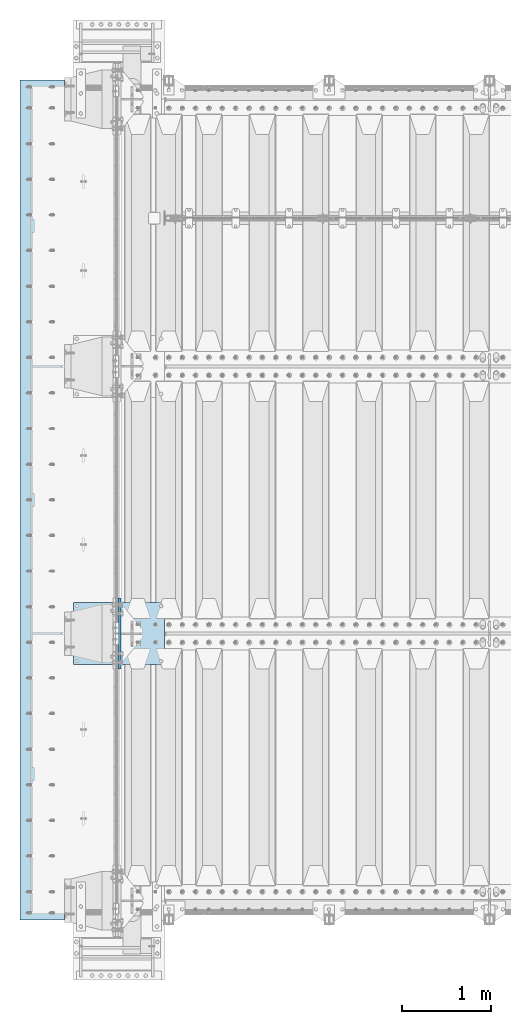
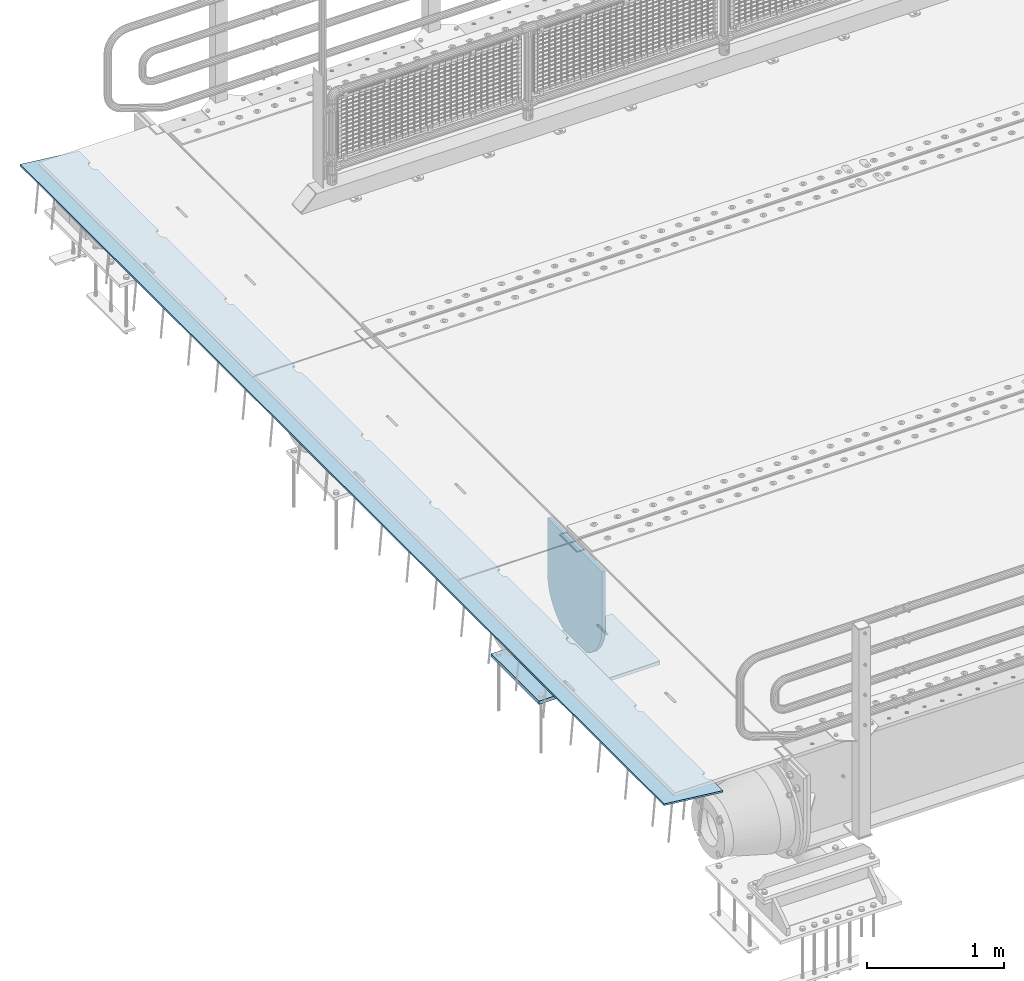
# One storey, part 169 of 219: 3 plates.
"""IFC2X3 building model written with IfcOpenShell, lengths in millimetres."""

from ifc_helpers import new_model, si_unit, frame, origin_with_axes, place, context, subcontext, project, spatial, faceted_brep, material, type_object, element, save


model = new_model("IFC2X3")

# Units and contexts
model_context = context("Model", 3, precision=1e-05, world=origin_with_axes())
body_context = subcontext(model_context, "Body", "Model", "MODEL_VIEW")
ifc_project = project(units=[si_unit("LENGTHUNIT", "METRE", prefix="MILLI"), si_unit("AREAUNIT", "SQUARE_METRE"), si_unit("VOLUMEUNIT", "CUBIC_METRE"), si_unit("MASSUNIT", "GRAM", prefix="KILO"), si_unit("TIMEUNIT", "SECOND"), si_unit("PLANEANGLEUNIT", "RADIAN"), si_unit("SOLIDANGLEUNIT", "STERADIAN"), si_unit("THERMODYNAMICTEMPERATUREUNIT", "DEGREE_CELSIUS"), si_unit("LUMINOUSINTENSITYUNIT", "LUMEN")], contexts=[model_context])

# Site, building, storey
site_placement = place(None, origin_with_axes())
site = spatial("IfcSite", under=ifc_project, at=site_placement, CompositionType="ELEMENT")
building_placement = place(site_placement, origin_with_axes())
building = spatial("IfcBuilding", under=site, at=building_placement, Name="Standard", CompositionType="ELEMENT")
storey_placement = place(building_placement, origin_with_axes())
storey = spatial("IfcBuildingStorey", under=building, at=storey_placement, Name="Undefined", CompositionType="ELEMENT", Elevation=0.0)

# Plates
ifc_material = material(Name="STEEL/S355N")
plate_type_1 = type_object("IfcPlateType", PredefinedType="NOTDEFINED")
plate_1_placement = place(storey_placement, frame((-624.181254970226, 23784.9999999981, -62.544823504668), z_axis=(-0.99402353270819, -1.00000033824219e-09, 0.109166003967953), x_axis=(0.0, 1.0, 0.0)))
element("IfcPlate", 1, at=plate_1_placement, inside=storey, type_object=plate_type_1, material=ifc_material, context=body_context, shape_type="Brep", body=[
    faceted_brep([(9165.000000001, -7.50000000000003, 7.55625608235277e-05), (9165.00000000271, 7.5, -1.22668097901624e-10), (9165.45576741756, 7.50000000000006, 5.20977563143788), (9165.45576741592, -7.50000000000003, 5.20977563143788), (9166.8092213894, 7.50000000000006, 10.260934599855), (9166.80922138775, -7.50000000000001, 10.260934599855), (9169.01923790418, 7.50000000000003, 15.000330297888), (9169.01923790254, -7.50000000000003, 15.000330297888), (9172.01866672843, 7.50000000000009, 19.283958585503), (9172.01866672678, -7.5, 19.2839585855029), (9175.71637173509, 7.50000000000003, 22.9816635848008), (9175.71637173346, -7.50000000000004, 22.9816635848008), (9180.00000002869, 7.50000000000003, 25.9810924005067), (9180.00000002705, -7.50000000000003, 25.9810924005067), (9184.73939573113, 7.50000000000009, 28.1911089058397), (9184.73939572949, -7.5, 28.1911089058397), (9189.79055470225, 7.50000000000006, 29.5445628676079), (9189.79055470061, -7.50000000000003, 29.5445628676079), (9195.00000003271, 7.50000000000003, 30.0003302720633), (9195.00000003107, -7.50000000000001, 30.0003302720631), (9235.00000003271, 7.50000000000003, 30.0003302323023), (9235.00000003107, -7.50000000000003, 30.0003302323022), (9240.20944536226, 7.50000000000006, 29.5445628174901), (9240.20944536063, -7.50000000000003, 29.5445628174901), (9245.26060433067, 7.50000000000003, 28.1911088456803), (9245.26060432904, -7.50000000000003, 28.1911088456803), (9250.00000002869, 7.50000000000006, 25.9810923309251), (9250.00000002705, -7.50000000000003, 25.981092330925), (9254.28362831629, 7.50000000000009, 22.9816635067032), (9254.28362831465, -7.50000000000003, 22.9816635067032), (9257.98133331556, 7.50000000000003, 19.2839585000545), (9257.98133331392, -7.50000000000004, 19.2839585000544), (9260.98076213124, 7.50000000000003, 15.000330206477), (9260.98076212961, -7.5, 15.0003302064769), (9263.19077863655, 7.50000000000006, 10.2609345040501), (9263.1907786349, -7.50000000000003, 10.2609345040501), (9264.54423259829, 7.50000000000003, 5.20977553294256), (9264.54423259664, -7.50000000000003, 5.20977553294244), (9265.00000000107, -7.50000000000001, 0.000330202481563902), (9265.00000000271, 7.5, -1.24146026792005e-10), (8265.00000000107, -7.50000000000001, 0.00033219055490008), (8264.54423259665, -7.50000000000001, 5.20977752101589), (8264.54423259829, 7.50000000000003, 5.20977752101589), (8265.00000000271, 7.50000000000003, -1.10617293103132e-10), (8263.19077863491, -7.5, 10.2609364921234), (8263.19077863655, 7.50000000000003, 10.2609364921234), (8260.98076212961, -7.50000000000001, 15.0003321945502), (8260.98076213124, 7.50000000000003, 15.0003321945502), (8257.98133331392, -7.5, 19.2839604881278), (8257.98133331557, 7.50000000000003, 19.2839604881278), (8254.28362831465, -7.50000000000003, 22.9816654947765), (8254.28362831629, 7.50000000000003, 22.9816654947766), (8250.00000002706, -7.50000000000001, 25.9810943189984), (8250.00000002869, 7.50000000000006, 25.9810943189984), (8245.26060432903, -7.5, 28.1911108337537), (8245.26060433067, 7.50000000000006, 28.1911108337537), (8240.20944536063, -7.50000000000003, 29.5445648055635), (8240.20944536226, 7.50000000000003, 29.5445648055634), (8235.00000003107, -7.5, 30.0003322203755), (8235.00000003271, 7.50000000000003, 30.0003322203756), (8195.00000003107, -7.50000000000001, 30.0003322601365), (8195.00000003271, 7.50000000000003, 30.0003322601366), (8189.79055470061, -7.50000000000001, 29.5445648556811), (8189.79055470225, 7.50000000000003, 29.5445648556811), (8184.7393957295, -7.50000000000003, 28.191110893913), (8184.73939573113, 7.50000000000003, 28.191110893913), (8180.00000002706, -7.5, 25.9810943885799), (8180.00000002869, 7.50000000000003, 25.9810943885799), (8175.71637173346, -7.5, 22.9816655728739), (8175.7163717351, 7.50000000000003, 22.9816655728739), (8172.01866672678, -7.5, 19.2839605735762), (8172.01866672843, 7.50000000000003, 19.2839605735761), (8169.01923790254, -7.5, 15.0003322859613), (8169.01923790418, 7.50000000000006, 15.0003322859613), (8166.80922138775, -7.5, 10.2609365879282), (8166.80922138939, 7.50000000000003, 10.2609365879282), (8165.45576741592, -7.50000000000003, 5.20977761951121), (8165.45576741755, 7.50000000000003, 5.2097776195111), (8165.00000000105, -7.5, 0.000195259053725749), (8165.00000000271, 7.50000000000003, -1.09253051050473e-10), (7265.00000000107, -7.5, 0.000334178628349946), (7265.00000000271, 7.50000000000003, -9.72022462519817e-11), (7264.54423259665, -7.5, 5.20977950908923), (7264.54423259829, 7.50000000000006, 5.20977950908923), (7263.19077863491, -7.5, 10.2609384801967), (7263.19077863655, 7.50000000000009, 10.2609384801968), (7260.98076212961, -7.49999999999999, 15.0003341826235), (7260.98076213124, 7.50000000000006, 15.0003341826235), (7257.98133331392, -7.5, 19.2839624762011), (7257.98133331557, 7.50000000000006, 19.2839624762012), (7254.28362831465, -7.5, 22.98166748285), (7254.28362831629, 7.50000000000006, 22.98166748285), (7250.00000002706, -7.5, 25.9810963070718), (7250.00000002869, 7.50000000000009, 25.9810963070718), (7245.26060432903, -7.49999999999997, 28.1911128218271), (7245.26060433067, 7.50000000000009, 28.191112821827), (7240.20944536063, -7.5, 29.5445667936369), (7240.20944536226, 7.50000000000009, 29.5445667936369), (7235.00000003107, -7.50000000000001, 30.000334208449), (7235.00000003271, 7.50000000000009, 30.000334208449), (7195.00000003107, -7.5, 30.0003342482099), (7195.00000003271, 7.50000000000006, 30.0003342482099), (7189.79055470061, -7.5, 29.5445668437545), (7189.79055470225, 7.50000000000009, 29.5445668437545), (7184.7393957295, -7.49999999999999, 28.1911128819866), (7184.73939573113, 7.50000000000009, 28.1911128819863), (7180.00000002706, -7.49999999999999, 25.9810963766533), (7180.00000002869, 7.50000000000006, 25.9810963766533), (7175.71637173346, -7.5, 22.9816675609474), (7175.7163717351, 7.50000000000009, 22.9816675609475), (7172.01866672678, -7.5, 19.2839625616497), (7172.01866672843, 7.50000000000009, 19.2839625616497), (7169.01923790254, -7.5, 15.0003342740349), (7169.01923790418, 7.50000000000003, 15.0003342740347), (7166.80922138775, -7.5, 10.2609385760016), (7166.80922138939, 7.50000000000009, 10.2609385760016), (7165.45576741592, -7.5, 5.20977960758444), (7165.45576741755, 7.50000000000009, 5.20977960758455), (7165.00000000106, -7.50000000000003, 0.000240574238659974), (7165.00000000271, 7.50000000000003, -9.59516910370439e-11), (6265.00000000107, -7.5, 0.000336166701572438), (6265.00000000271, 7.50000000000003, -8.3787199400831e-11), (6264.54423259665, -7.50000000000003, 5.20978149716257), (6264.54423259829, 7.50000000000003, 5.20978149716268), (6263.19077863491, -7.50000000000003, 10.2609404682702), (6263.19077863655, 7.50000000000003, 10.2609404682701), (6260.98076212961, -7.50000000000003, 15.0003361706968), (6260.98076213124, 7.50000000000003, 15.0003361706969), (6257.98133331392, -7.50000000000006, 19.2839644642744), (6257.98133331557, 7.50000000000003, 19.2839644642745), (6254.28362831465, -7.50000000000006, 22.9816694709233), (6254.28362831629, 7.50000000000003, 22.9816694709232), (6250.00000002706, -7.50000000000004, 25.981098295145), (6250.00000002869, 7.50000000000003, 25.9810982951451), (6245.26060432903, -7.50000000000004, 28.1911148099002), (6245.26060433067, 7.5, 28.1911148099003), (6240.20944536063, -7.50000000000006, 29.5445687817103), (6240.20944536226, 7.50000000000003, 29.5445687817102), (6235.00000003107, -7.50000000000006, 30.0003361965222), (6235.00000003271, 7.50000000000003, 30.0003361965223), (6195.00000003107, -7.50000000000004, 30.0003362362831), (6195.00000003271, 7.50000000000003, 30.0003362362833), (6189.79055470061, -7.50000000000003, 29.5445688318279), (6189.79055470225, 7.5, 29.5445688318277), (6184.7393957295, -7.50000000000009, 28.1911148700598), (6184.73939573113, 7.50000000000003, 28.1911148700598), (6180.00000002706, -7.50000000000004, 25.9810983647266), (6180.00000002869, 7.50000000000003, 25.9810983647267), (6175.71637173346, -7.50000000000006, 22.9816695490207), (6175.7163717351, 7.50000000000003, 22.9816695490208), (6172.01866672678, -7.50000000000006, 19.2839645497229), (6172.01866672843, 7.50000000000003, 19.2839645497229), (6169.01923790254, -7.50000000000006, 15.0003362621081), (6169.01923790418, 7.50000000000003, 15.0003362621081), (6166.80922138775, -7.50000000000006, 10.2609405640749), (6166.80922138939, 7.50000000000003, 10.2609405640749), (6165.45576741592, -7.50000000000003, 5.20978159565789), (6165.45576741755, 7.49999999999997, 5.20978159565789), (6165.00000000107, -7.5, 0.000265084087914147), (6165.00000000271, 7.50000000000003, -8.25366441858932e-11), (5265.00000000107, -7.50000000000001, 0.000338154774908617), (5265.00000000271, 7.5, -7.03721525496803e-11), (5264.54423259665, -7.5, 5.20978348523579), (5264.54423259829, 7.5, 5.20978348523579), (5263.19077863491, -7.50000000000003, 10.2609424563434), (5263.19077863655, 7.5, 10.2609424563434), (5260.98076212961, -7.5, 15.0003381587702), (5260.98076213124, 7.49999999999997, 15.0003381587701), (5257.98133331392, -7.5, 19.2839664523478), (5257.98133331557, 7.50000000000003, 19.2839664523477), (5254.28362831465, -7.5, 22.9816714589966), (5254.28362831629, 7.50000000000003, 22.9816714589965), (5250.00000002706, -7.5, 25.9811002832184), (5250.00000002869, 7.50000000000003, 25.9811002832183), (5245.26060432903, -7.5, 28.1911167979737), (5245.26060433067, 7.5, 28.1911167979736), (5240.20944536063, -7.5, 29.5445707697836), (5240.20944536226, 7.50000000000003, 29.5445707697835), (5235.00000003107, -7.50000000000001, 30.0003381845955), (5235.00000003271, 7.5, 30.0003381845956), (5195.00000003107, -7.5, 30.0003382243565), (5195.00000003271, 7.5, 30.0003382243566), (5189.79055470061, -7.5, 29.5445708199011), (5189.79055470225, 7.50000000000003, 29.5445708199012), (5184.7393957295, -7.5, 28.191116858133), (5184.73939573113, 7.50000000000003, 28.191116858133), (5180.00000002706, -7.50000000000001, 25.9811003528), (5180.00000002869, 7.49999999999997, 25.9811003527999), (5175.71637173346, -7.49999999999999, 22.981671537094), (5175.7163717351, 7.50000000000003, 22.981671537094), (5172.01866672678, -7.50000000000001, 19.2839665377961), (5172.01866672843, 7.50000000000003, 19.2839665377961), (5169.01923790254, -7.49999999999999, 15.0003382501815), (5169.01923790418, 7.50000000000003, 15.0003382501814), (5166.80922138775, -7.50000000000003, 10.2609425521481), (5166.80922138939, 7.49999999999997, 10.2609425521482), (5165.45576741592, -7.50000000000003, 5.20978358373111), (5165.45576741755, 7.5, 5.20978358373111), (5165.00000000107, -7.5, 0.000280873017231897), (5165.00000000271, 7.50000000000003, -6.91215973347425e-11), (4265.00000000107, -7.5, 0.000340142848244795), (4265.00000000271, 7.50000000000003, -5.70707925362512e-11), (4264.54423259665, -7.49999999999997, 5.20978547330924), (4264.54423259829, 7.50000000000003, 5.20978547330924), (4263.19077863491, -7.5, 10.2609444444167), (4263.19077863655, 7.49999999999997, 10.2609444444167), (4260.98076212961, -7.5, 15.0003401468437), (4260.98076213124, 7.49999999999997, 15.0003401468437), (4257.98133331392, -7.5, 19.2839684404212), (4257.98133331557, 7.49999999999997, 19.2839684404212), (4254.28362831465, -7.49999999999999, 22.98167344707), (4254.28362831629, 7.50000000000003, 22.9816734470699), (4250.00000002706, -7.5, 25.9811022712918), (4250.00000002869, 7.5, 25.9811022712918), (4245.26060432903, -7.5, 28.191118786047), (4245.26060433067, 7.49999999999997, 28.191118786047), (4240.20944536063, -7.49999999999999, 29.5445727578569), (4240.20944536226, 7.5, 29.5445727578569), (4235.00000003107, -7.5, 30.000340172669), (4235.00000003271, 7.49999999999997, 30.000340172669), (4195.00000003107, -7.5, 30.0003402124299), (4195.00000003271, 7.49999999999997, 30.0003402124299), (4189.79055470061, -7.5, 29.5445728079745), (4189.79055470225, 7.49999999999997, 29.5445728079744), (4184.7393957295, -7.49999999999997, 28.1911188462065), (4184.73939573113, 7.5, 28.1911188462065), (4180.00000002706, -7.5, 25.9811023408733), (4180.00000002869, 7.5, 25.9811023408733), (4175.71637173346, -7.5, 22.9816735251673), (4175.7163717351, 7.49999999999997, 22.9816735251674), (4172.01866672678, -7.49999999999997, 19.2839685258697), (4172.01866672843, 7.49999999999997, 19.2839685258696), (4169.01923790254, -7.5, 15.0003402382548), (4169.01923790418, 7.49999999999997, 15.0003402382547), (4166.80922138775, -7.49999999999999, 10.2609445402217), (4166.80922138939, 7.5, 10.2609445402215), (4165.45576741592, -7.5, 5.20978557180456), (4165.45576741755, 7.49999999999997, 5.20978557180456), (4165.00000000107, -7.5, 0.000292184783234006), (4165.00000000271, 7.5, -5.57065504835919e-11), (3265.00000000107, -7.5, 0.000342130921580974), (3265.00000000271, 7.50000000000003, -4.36557456851006e-11), (3264.54423259665, -7.49999999999999, 5.20978746138246), (3264.54423259829, 7.49999999999991, 5.20978746138258), (3263.19077863491, -7.49999999999997, 10.2609464324901), (3263.19077863655, 7.49999999999997, 10.2609464324901), (3260.98076212961, -7.49999999999997, 15.0003421349168), (3260.98076213124, 7.49999999999997, 15.0003421349169), (3257.98133331392, -7.49999999999997, 19.2839704284945), (3257.98133331557, 7.49999999999997, 19.2839704284945), (3254.28362831465, -7.49999999999997, 22.9816754351434), (3254.28362831629, 7.49999999999997, 22.9816754351433), (3250.00000002706, -7.49999999999997, 25.9811042593651), (3250.00000002869, 7.49999999999991, 25.9811042593651), (3245.26060432903, -7.5, 28.1911207741204), (3245.26060433067, 7.49999999999997, 28.1911207741204), (3240.20944536063, -7.5, 29.5445747459303), (3240.20944536226, 7.49999999999997, 29.5445747459304), (3235.00000003107, -7.49999999999997, 30.0003421607422), (3235.00000003271, 7.49999999999997, 30.0003421607423), (3195.00000003107, -7.49999999999997, 30.0003422005032), (3195.00000003271, 7.49999999999997, 30.0003422005033), (3189.79055470061, -7.49999999999996, 29.5445747960478), (3189.79055470225, 7.49999999999997, 29.5445747960478), (3184.7393957295, -7.49999999999999, 28.1911208342797), (3184.73939573113, 7.49999999999997, 28.1911208342797), (3180.00000002706, -7.49999999999997, 25.9811043289466), (3180.00000002869, 7.49999999999994, 25.9811043289466), (3175.71637173346, -7.49999999999997, 22.9816755132407), (3175.7163717351, 7.49999999999994, 22.9816755132407), (3172.01866672678, -7.5, 19.2839705139428), (3172.01866672843, 7.49999999999994, 19.2839705139429), (3169.01923790254, -7.49999999999997, 15.0003422263281), (3169.01923790418, 7.49999999999997, 15.0003422263281), (3166.80922138775, -7.49999999999997, 10.2609465282949), (3166.80922138939, 7.49999999999997, 10.2609465282949), (3165.45576741592, -7.49999999999997, 5.20978755987778), (3165.45576741755, 7.49999999999997, 5.2097875598779), (3165.00000000107, -7.5, 0.000300893983080641), (3165.00000000271, 7.50000000000003, -4.24051904701628e-11), (2265.00000000107, -7.5, 0.000344118994917153), (2265.00000000271, 7.5, -3.03543856716715e-11), (2264.54423259665, -7.50000000000003, 5.2097894494558), (2264.54423259829, 7.49999999999997, 5.20978944945591), (2263.19077863491, -7.50000000000003, 10.2609484205634), (2263.19077863655, 7.49999999999997, 10.2609484205633), (2260.98076212961, -7.50000000000004, 15.0003441229902), (2260.98076213124, 7.49999999999997, 15.0003441229902), (2257.98133331392, -7.50000000000003, 19.2839724165678), (2257.98133331557, 7.5, 19.2839724165677), (2254.28362831465, -7.5, 22.9816774232165), (2254.28362831629, 7.49999999999997, 22.9816774232166), (2250.00000002706, -7.50000000000003, 25.9811062474383), (2250.00000002869, 7.49999999999997, 25.9811062474384), (2245.26060432903, -7.50000000000003, 28.1911227621936), (2245.26060433067, 7.5, 28.1911227621937), (2240.20944536063, -7.50000000000003, 29.5445767340036), (2240.20944536226, 7.49999999999997, 29.5445767340035), (2235.00000003107, -7.50000000000003, 30.0003441488155), (2235.00000003271, 7.49999999999997, 30.0003441488157), (2195.00000003107, -7.50000000000003, 30.0003441885765), (2195.00000003271, 7.49999999999997, 30.0003441885766), (2189.79055470061, -7.50000000000003, 29.5445767841211), (2189.79055470225, 7.49999999999997, 29.5445767841211), (2184.7393957295, -7.50000000000006, 28.191122822353), (2184.73939573113, 7.49999999999997, 28.1911228223531), (2180.00000002706, -7.50000000000001, 25.9811063170199), (2180.00000002869, 7.5, 25.9811063170199), (2175.71637173346, -7.50000000000003, 22.9816775013139), (2175.7163717351, 7.5, 22.9816775013139), (2172.01866672678, -7.5, 19.2839725020162), (2172.01866672843, 7.5, 19.2839725020161), (2169.01923790254, -7.50000000000004, 15.0003442144014), (2169.01923790418, 7.49999999999997, 15.0003442144015), (2166.80922138775, -7.50000000000003, 10.2609485163682), (2166.80922138939, 7.49999999999997, 10.2609485163682), (2165.45576741592, -7.50000000000003, 5.20978954795123), (2165.45576741755, 7.49999999999997, 5.20978954795112), (2165.00000000107, -7.5, 0.000307956857113822), (2165.00000000271, 7.5, -2.89901436190121e-11), (1265.00000000107, -7.49999999999999, 0.000346107068367019), (1265.00000000271, 7.50000000000003, -1.69393388205208e-11), (1264.54423259665, -7.50000000000006, 5.20979143752925), (1264.54423259829, 7.49999999999997, 5.20979143752925), (1263.19077863491, -7.50000000000003, 10.2609504086367), (1263.19077863655, 7.50000000000003, 10.2609504086369), (1260.98076212961, -7.50000000000003, 15.0003461110637), (1260.98076213124, 7.50000000000003, 15.0003461110636), (1257.98133331392, -7.50000000000003, 19.2839744046413), (1257.98133331557, 7.5, 19.2839744046413), (1254.28362831465, -7.50000000000003, 22.9816794112901), (1254.28362831629, 7.5, 22.9816794112901), (1250.00000002706, -7.50000000000001, 25.9811082355119), (1250.00000002869, 7.50000000000003, 25.9811082355118), (1245.26060432903, -7.50000000000003, 28.1911247502671), (1245.26060433067, 7.5, 28.191124750267), (1240.20944536063, -7.50000000000004, 29.5445787220769), (1240.20944536226, 7.5, 29.5445787220771), (1235.00000003107, -7.50000000000004, 30.0003461368889), (1235.00000003271, 7.5, 30.0003461368889), (1195.00000003107, -7.50000000000003, 30.0003461766498), (1195.00000003271, 7.50000000000003, 30.0003461766498), (1189.79055470061, -7.50000000000003, 29.5445787721944), (1189.79055470225, 7.49999999999997, 29.5445787721944), (1184.7393957295, -7.50000000000001, 28.1911248104265), (1184.73939573113, 7.50000000000003, 28.1911248104263), (1180.00000002706, -7.50000000000003, 25.9811083050934), (1180.00000002869, 7.5, 25.9811083050932), (1175.71637173346, -7.50000000000003, 22.9816794893874), (1175.7163717351, 7.5, 22.9816794893874), (1172.01866672678, -7.50000000000003, 19.2839744900897), (1172.01866672843, 7.5, 19.2839744900896), (1169.01923790254, -7.50000000000003, 15.0003462024749), (1169.01923790418, 7.50000000000003, 15.0003462024748), (1166.80922138775, -7.50000000000003, 10.2609505044416), (1166.80922138939, 7.50000000000003, 10.2609505044416), (1165.45576741592, -7.50000000000006, 5.20979153602445), (1165.45576741755, 7.5, 5.20979153602457), (1165.00000000107, -7.49999999999999, 0.000313912300271113), (1165.00000000271, 7.5, -1.5688783605583e-11), (265.000000001073, -7.5, 0.000348095141589511), (265.000000002707, 7.49999999999997, -3.5242919693701e-12), (264.544232596651, -7.49999999999999, 5.20979342560247), (264.544232598288, 7.50000000000003, 5.20979342560258), (263.190778634911, -7.5, 10.2609523967102), (263.190778636552, 7.5, 10.26095239671), (260.980762129606, -7.5, 15.0003480991368), (260.980762131243, 7.49999999999997, 15.0003480991369), (257.981333313925, -7.5, 19.2839763927145), (257.981333315565, 7.49999999999997, 19.2839763927146), (254.28362831465, -7.50000000000001, 22.9816813993633), (254.283628316287, 7.5, 22.9816813993633), (250.000000027056, -7.50000000000001, 25.981110223585), (250.000000028689, 7.5, 25.9811102235851), (245.260604329033, -7.5, 28.1911267383402), (245.26060433067, 7.50000000000003, 28.1911267383404), (240.209445360626, -7.5, 29.5445807101503), (240.209445362263, 7.49999999999997, 29.5445807101503), (235.000000031072, -7.50000000000001, 30.0003481249623), (235.000000032709, 7.49999999999997, 30.0003481249623), (195.000000031072, -7.5, 30.0003481647233), (195.000000032709, 7.5, 30.0003481647233), (189.790554700608, -7.5, 29.5445807602679), (189.790554702246, 7.49999999999997, 29.5445807602678), (184.739395729495, -7.5, 28.1911267984998), (184.739395731132, 7.5, 28.1911267984998), (180.000000027056, -7.5, 25.9811102931666), (180.000000028689, 7.5, 25.9811102931667), (175.716371733459, -7.5, 22.9816814774607), (175.716371735096, 7.5, 22.9816814774608), (172.018666726784, -7.5, 19.283976478163), (172.018666728425, 7.5, 19.2839764781629), (169.019237902539, -7.50000000000001, 15.000348190548), (169.019237904176, 7.49999999999997, 15.0003481905482), (166.809221387754, -7.5, 10.260952492515), (166.809221389394, 7.49999999999997, 10.2609524925149), (165.455767415915, -7.5, 5.2097935240979), (165.455767417552, 7.50000000000003, 5.2097935240979), (165.000000001073, -7.5, -2.1600499167107e-12), (165.000000002707, 7.5, -2.1600499167107e-12), (0.0, -7.49999999999999, 0.0), (0.0, 7.5, 0.0), (7.81546987127513e-08, -7.5, 500.00244140625), (7.81546987127513e-08, 7.5, 500.00244140625), (9430.00000000299, -7.5, 500.002380371094), (9430.000000003, 7.5, 500.002380371094), (9430.0, -7.50000000000003, -1.26306076708715e-10), (9430.00000000001, 7.5, -1.26192389870994e-10)], [[[0, 1, 2, 3]], [[3, 2, 4, 5]], [[5, 4, 6, 7]], [[7, 6, 8, 9]], [[9, 8, 10, 11]], [[11, 10, 12, 13]], [[13, 12, 14, 15]], [[15, 14, 16, 17]], [[17, 16, 18, 19]], [[19, 18, 20, 21]], [[21, 20, 22, 23]], [[23, 22, 24, 25]], [[25, 24, 26, 27]], [[27, 26, 28, 29]], [[29, 28, 30, 31]], [[31, 30, 32, 33]], [[33, 32, 34, 35]], [[35, 34, 36, 37]], [[38, 37, 36, 39]], [[40, 41, 42, 43]], [[44, 45, 42, 41]], [[46, 47, 45, 44]], [[48, 49, 47, 46]], [[50, 51, 49, 48]], [[52, 53, 51, 50]], [[54, 55, 53, 52]], [[56, 57, 55, 54]], [[58, 59, 57, 56]], [[60, 61, 59, 58]], [[62, 63, 61, 60]], [[64, 65, 63, 62]], [[66, 67, 65, 64]], [[68, 69, 67, 66]], [[70, 71, 69, 68]], [[72, 73, 71, 70]], [[74, 75, 73, 72]], [[76, 77, 75, 74]], [[78, 79, 77, 76]], [[80, 81, 79, 78]], [[80, 82, 83, 81]], [[84, 85, 83, 82]], [[86, 87, 85, 84]], [[88, 89, 87, 86]], [[90, 91, 89, 88]], [[92, 93, 91, 90]], [[94, 95, 93, 92]], [[96, 97, 95, 94]], [[98, 99, 97, 96]], [[100, 101, 99, 98]], [[102, 103, 101, 100]], [[104, 105, 103, 102]], [[106, 107, 105, 104]], [[108, 109, 107, 106]], [[110, 111, 109, 108]], [[112, 113, 111, 110]], [[114, 115, 113, 112]], [[116, 117, 115, 114]], [[118, 119, 117, 116]], [[120, 121, 119, 118]], [[120, 122, 123, 121]], [[124, 125, 123, 122]], [[126, 127, 125, 124]], [[128, 129, 127, 126]], [[130, 131, 129, 128]], [[132, 133, 131, 130]], [[134, 135, 133, 132]], [[136, 137, 135, 134]], [[138, 139, 137, 136]], [[140, 141, 139, 138]], [[142, 143, 141, 140]], [[144, 145, 143, 142]], [[146, 147, 145, 144]], [[148, 149, 147, 146]], [[150, 151, 149, 148]], [[152, 153, 151, 150]], [[154, 155, 153, 152]], [[156, 157, 155, 154]], [[158, 159, 157, 156]], [[160, 161, 159, 158]], [[160, 162, 163, 161]], [[164, 165, 163, 162]], [[166, 167, 165, 164]], [[168, 169, 167, 166]], [[170, 171, 169, 168]], [[172, 173, 171, 170]], [[174, 175, 173, 172]], [[176, 177, 175, 174]], [[178, 179, 177, 176]], [[180, 181, 179, 178]], [[182, 183, 181, 180]], [[184, 185, 183, 182]], [[186, 187, 185, 184]], [[188, 189, 187, 186]], [[190, 191, 189, 188]], [[192, 193, 191, 190]], [[194, 195, 193, 192]], [[196, 197, 195, 194]], [[198, 199, 197, 196]], [[200, 201, 199, 198]], [[200, 202, 203, 201]], [[204, 205, 203, 202]], [[206, 207, 205, 204]], [[208, 209, 207, 206]], [[210, 211, 209, 208]], [[212, 213, 211, 210]], [[214, 215, 213, 212]], [[216, 217, 215, 214]], [[218, 219, 217, 216]], [[220, 221, 219, 218]], [[222, 223, 221, 220]], [[224, 225, 223, 222]], [[226, 227, 225, 224]], [[228, 229, 227, 226]], [[230, 231, 229, 228]], [[232, 233, 231, 230]], [[234, 235, 233, 232]], [[236, 237, 235, 234]], [[238, 239, 237, 236]], [[240, 241, 239, 238]], [[240, 242, 243, 241]], [[244, 245, 243, 242]], [[246, 247, 245, 244]], [[248, 249, 247, 246]], [[250, 251, 249, 248]], [[252, 253, 251, 250]], [[254, 255, 253, 252]], [[256, 257, 255, 254]], [[258, 259, 257, 256]], [[260, 261, 259, 258]], [[262, 263, 261, 260]], [[264, 265, 263, 262]], [[266, 267, 265, 264]], [[268, 269, 267, 266]], [[270, 271, 269, 268]], [[272, 273, 271, 270]], [[274, 275, 273, 272]], [[276, 277, 275, 274]], [[278, 279, 277, 276]], [[280, 281, 279, 278]], [[280, 282, 283, 281]], [[284, 285, 283, 282]], [[286, 287, 285, 284]], [[288, 289, 287, 286]], [[290, 291, 289, 288]], [[292, 293, 291, 290]], [[294, 295, 293, 292]], [[296, 297, 295, 294]], [[298, 299, 297, 296]], [[300, 301, 299, 298]], [[302, 303, 301, 300]], [[304, 305, 303, 302]], [[306, 307, 305, 304]], [[308, 309, 307, 306]], [[310, 311, 309, 308]], [[312, 313, 311, 310]], [[314, 315, 313, 312]], [[316, 317, 315, 314]], [[318, 319, 317, 316]], [[320, 321, 319, 318]], [[320, 322, 323, 321]], [[324, 325, 323, 322]], [[326, 327, 325, 324]], [[328, 329, 327, 326]], [[330, 331, 329, 328]], [[332, 333, 331, 330]], [[334, 335, 333, 332]], [[336, 337, 335, 334]], [[338, 339, 337, 336]], [[340, 341, 339, 338]], [[342, 343, 341, 340]], [[344, 345, 343, 342]], [[346, 347, 345, 344]], [[348, 349, 347, 346]], [[350, 351, 349, 348]], [[352, 353, 351, 350]], [[354, 355, 353, 352]], [[356, 357, 355, 354]], [[358, 359, 357, 356]], [[360, 361, 359, 358]], [[360, 362, 363, 361]], [[364, 365, 363, 362]], [[366, 367, 365, 364]], [[368, 369, 367, 366]], [[370, 371, 369, 368]], [[372, 373, 371, 370]], [[374, 375, 373, 372]], [[376, 377, 375, 374]], [[378, 379, 377, 376]], [[380, 381, 379, 378]], [[382, 383, 381, 380]], [[384, 385, 383, 382]], [[386, 387, 385, 384]], [[388, 389, 387, 386]], [[390, 391, 389, 388]], [[392, 393, 391, 390]], [[394, 395, 393, 392]], [[396, 397, 395, 394]], [[398, 399, 397, 396]], [[400, 401, 399, 398]], [[400, 402, 403, 401]], [[402, 404, 405, 403]], [[404, 406, 407, 405]], [[407, 406, 38, 39]], [[34, 32, 30, 28, 26, 24, 22, 20, 18, 16, 14, 12, 10, 8, 6, 4, 2, 1, 43, 42, 45, 47, 49, 51, 53, 55, 57, 59, 61, 63, 65, 67, 69, 71, 73, 75, 77, 79, 81, 83, 85, 87, 89, 91, 93, 95, 97, 99, 101, 103, 105, 107, 109, 111, 113, 115, 117, 119, 121, 123, 125, 127, 129, 131, 133, 135, 137, 139, 141, 143, 145, 147, 149, 151, 153, 155, 157, 159, 161, 163, 165, 167, 169, 171, 173, 175, 177, 179, 181, 183, 185, 187, 189, 191, 193, 195, 197, 199, 201, 203, 205, 207, 209, 211, 213, 215, 217, 219, 221, 223, 225, 227, 229, 231, 233, 235, 237, 239, 241, 243, 245, 247, 249, 251, 253, 255, 257, 259, 261, 263, 265, 267, 269, 271, 273, 275, 277, 279, 281, 283, 285, 287, 289, 291, 293, 295, 297, 299, 301, 303, 305, 307, 309, 311, 313, 315, 317, 319, 321, 323, 325, 327, 329, 331, 333, 335, 337, 339, 341, 343, 345, 347, 349, 351, 353, 355, 357, 359, 361, 363, 365, 367, 369, 371, 373, 375, 377, 379, 381, 383, 385, 387, 389, 391, 393, 395, 397, 399, 401, 403, 405, 407, 39, 36]], [[40, 43, 1, 0]], [[406, 404, 402, 400, 398, 396, 394, 392, 390, 388, 386, 384, 382, 380, 378, 376, 374, 372, 370, 368, 366, 364, 362, 360, 358, 356, 354, 352, 350, 348, 346, 344, 342, 340, 338, 336, 334, 332, 330, 328, 326, 324, 322, 320, 318, 316, 314, 312, 310, 308, 306, 304, 302, 300, 298, 296, 294, 292, 290, 288, 286, 284, 282, 280, 278, 276, 274, 272, 270, 268, 266, 264, 262, 260, 258, 256, 254, 252, 250, 248, 246, 244, 242, 240, 238, 236, 234, 232, 230, 228, 226, 224, 222, 220, 218, 216, 214, 212, 210, 208, 206, 204, 202, 200, 198, 196, 194, 192, 190, 188, 186, 184, 182, 180, 178, 176, 174, 172, 170, 168, 166, 164, 162, 160, 158, 156, 154, 152, 150, 148, 146, 144, 142, 140, 138, 136, 134, 132, 130, 128, 126, 124, 122, 120, 118, 116, 114, 112, 110, 108, 106, 104, 102, 100, 98, 96, 94, 92, 90, 88, 86, 84, 82, 80, 78, 76, 74, 72, 70, 68, 66, 64, 62, 60, 58, 56, 54, 52, 50, 48, 46, 44, 41, 40, 0, 3, 5, 7, 9, 11, 13, 15, 17, 19, 21, 23, 25, 27, 29, 31, 33, 35, 37, 38]]]),
])
plate_type_2 = type_object("IfcPlateType", PredefinedType="NOTDEFINED")
plate_2_placement = place(storey_placement, frame((-523.999999999996, 27350.0, -1043.0), z_axis=(1.0, 0.0, 0.0), x_axis=(0.0, -1.0, 0.0)))
element("IfcPlate", 2, at=plate_2_placement, inside=storey, type_object=plate_type_2, material=ifc_material, context=body_context, shape_type="Brep", body=[
    faceted_brep([(0.0, -15.0, 0.0), (3.03448287013453e-05, -15.0, 1025.0), (3.03448287013453e-05, 15.0, 1025.0), (0.0, 15.0, 0.0), (700.0, -15.0, 1025.0), (700.0, 15.0, 1025.0), (700.0, -15.0, -6.3664629124105e-12), (700.0, 15.0, -6.3664629124105e-12)], [[[0, 1, 2, 3]], [[1, 4, 5, 2]], [[4, 6, 7, 5]], [[6, 0, 3, 7]], [[5, 7, 3, 2]], [[6, 4, 1, 0]]]),
])
plate_type_3 = type_object("IfcPlateType", PredefinedType="NOTDEFINED")
plate_3_placement = place(storey_placement, frame((-5.0, 26600.0, -20.0), z_axis=(0.0, 1.0, 0.0), x_axis=(0.0, 0.0, -1.0)))
element("IfcPlate", 3, at=plate_3_placement, inside=storey, type_object=plate_type_3, material=ifc_material, context=body_context, shape_type="Brep", body=[
    faceted_brep([(855.0, -15.0, 572.963114670027), (855.0, 15.0, 572.963114670027), (849.182410260917, 15.0, 585.889268816907), (849.182410260917, -15.0, 585.889268816907), (824.193546357179, 15.0, 627.225898691897), (824.193546357179, -15.0, 627.225898691897), (794.404299268237, 15.0, 665.249063295792), (794.404299268237, -15.0, 665.249063295792), (760.249063296204, 15.0, 699.404299267975), (760.249063296204, -15.0, 699.404299267975), (722.225898692443, 15.0, 729.193546357055), (722.225898692443, -15.0, 729.193546357055), (680.889268817573, 15.0, 754.182410260939), (680.889268817573, -15.0, 754.182410260939), (636.841954817181, 15.0, 774.006497073904), (636.841954817181, -15.0, 774.006497073904), (590.726265715286, 15.0, 788.376726970237), (590.726265715286, -15.0, 788.376726970237), (543.214672102495, 15.0, 797.083549639108), (543.214672102495, -15.0, 797.083549639108), (495.0, -15.0, 800.000000000029), (495.0, 15.0, 800.0), (494.999999999412, -15.0, 0.0), (494.999999999412, 15.0, 0.0), (543.214672105067, 15.0, 2.91645036483533), (543.214672105067, -15.0, 2.91645036483533), (590.726265717545, 15.0, 11.623273033314), (590.726265717545, -15.0, 11.623273033314), (636.841954819123, 15.0, 25.9935029292174), (636.841954819123, -15.0, 25.9935029292174), (680.889268819221, 15.0, 45.8175897417386), (680.889268819221, -15.0, 45.8175897417386), (722.225898693796, 15.0, 70.8064536451857), (722.225898693796, -15.0, 70.8064536451857), (760.249063297284, 15.0, 100.595700733822), (760.249063297284, -15.0, 100.595700733822), (794.404299269056, 15.0, 134.750936705557), (794.404299269056, -15.0, 134.750936705557), (824.193546357754, 15.0, 172.77410130902), (824.193546357754, -15.0, 172.77410130902), (849.182410261274, 15.0, 214.110731183588), (849.182410261274, -15.0, 214.110731183588), (855.0, -15.0, 227.03688532969), (855.0, 15.0, 227.03688532969), (0.0, -15.0, 0.0), (0.0, 15.0, 0.0), (0.0, 15.0, 800.0), (0.0, -15.0, 800.0)], [[[0, 1, 2, 3]], [[3, 2, 4, 5]], [[5, 4, 6, 7]], [[7, 6, 8, 9]], [[9, 8, 10, 11]], [[11, 10, 12, 13]], [[13, 12, 14, 15]], [[15, 14, 16, 17]], [[17, 16, 18, 19]], [[20, 19, 18, 21]], [[22, 23, 24, 25]], [[25, 24, 26, 27]], [[27, 26, 28, 29]], [[29, 28, 30, 31]], [[31, 30, 32, 33]], [[33, 32, 34, 35]], [[35, 34, 36, 37]], [[37, 36, 38, 39]], [[39, 38, 40, 41]], [[42, 41, 40, 43]], [[42, 43, 1, 0]], [[44, 45, 23, 22]], [[16, 14, 12, 10, 8, 6, 4, 2, 1, 43, 40, 38, 36, 34, 32, 30, 28, 26, 24, 23, 45, 46, 21, 18]], [[44, 47, 46, 45]], [[46, 47, 20, 21]], [[47, 44, 22, 25, 27, 29, 31, 33, 35, 37, 39, 41, 42, 0, 3, 5, 7, 9, 11, 13, 15, 17, 19, 20]]]),
])

save(model, "model.ifc")
